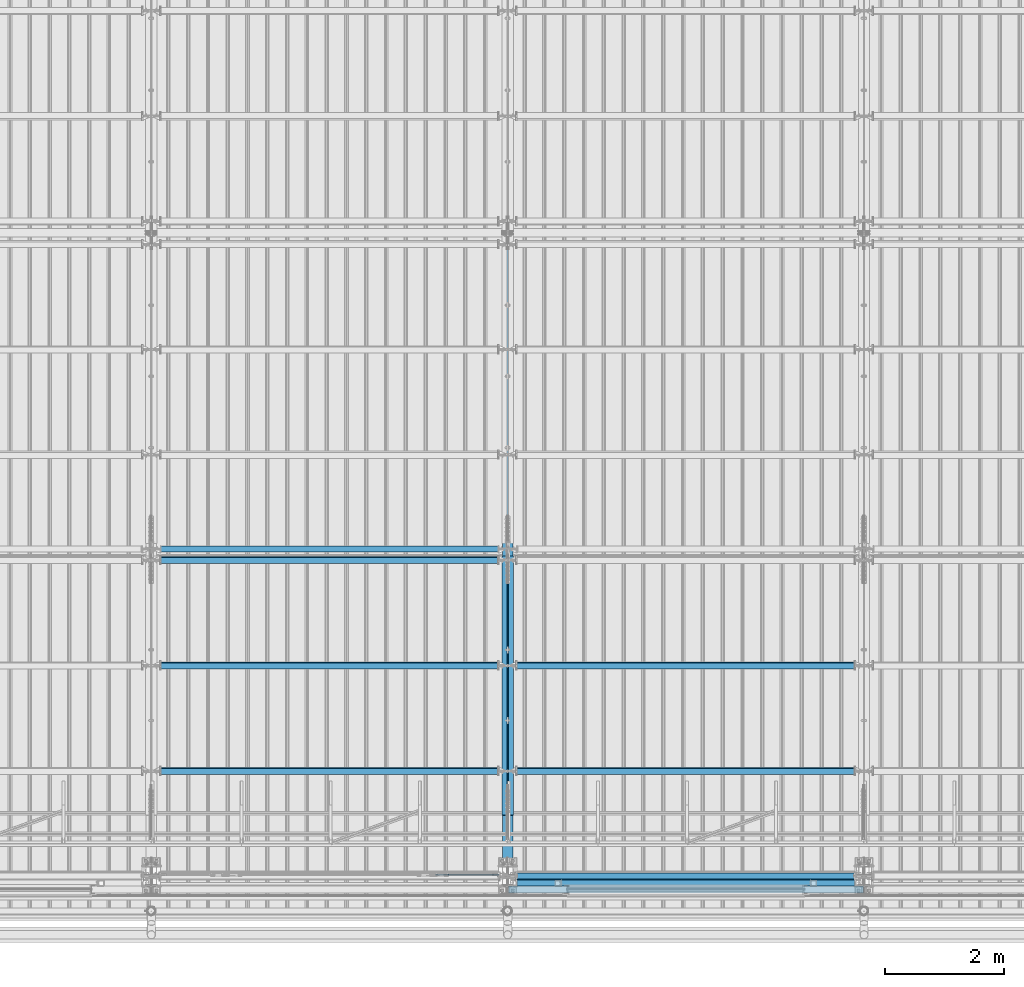
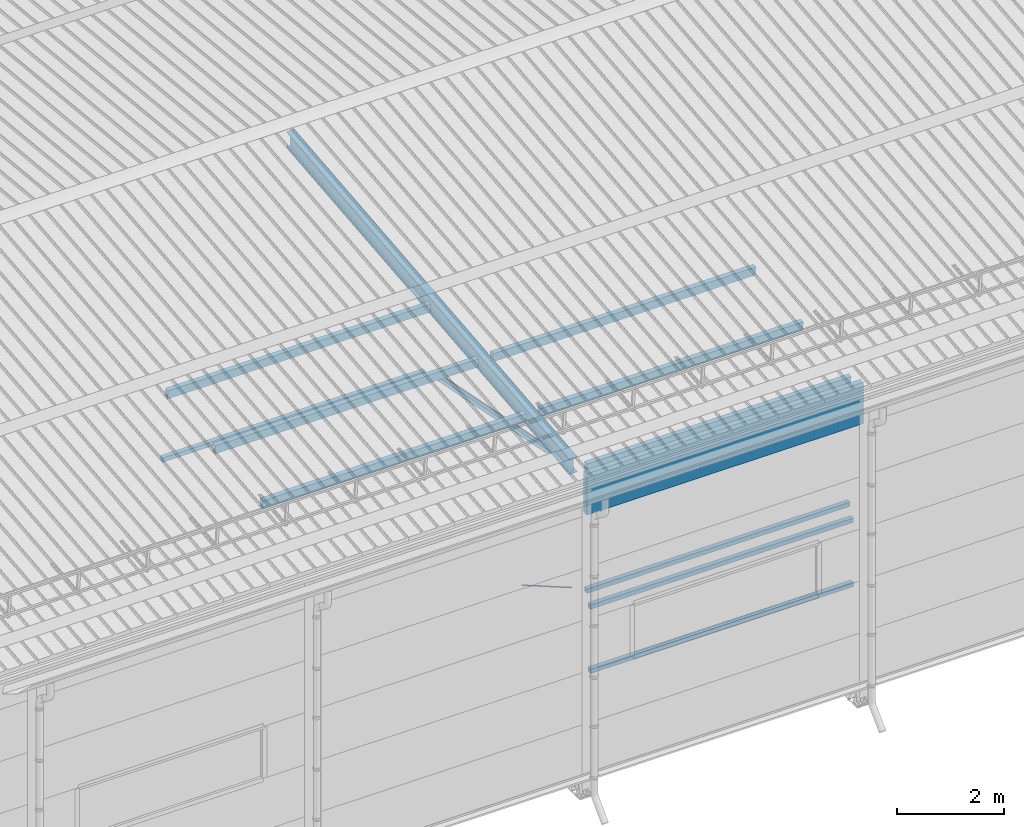
# One storey, part 254 of 709: 14 beams, 1 member, 1 opening, 15 elements without a shape of their own.
"""IFC4 building model written with IfcOpenShell, lengths in millimetres."""

from ifc_helpers import new_model, si_unit, direction, frame, origin_with_axes, place, context, subcontext, project, spatial, line, indexed_curve, outline, extrude, polygons, material, element, aggregate, save


model = new_model("IFC4")

# Units and contexts
model_context = context("Model", 3, precision=0.2, world=origin_with_axes(), true_north=direction((0.0, 1.0)))
body_context = subcontext(model_context, "Body", "Model", "MODEL_VIEW")
reference_context = subcontext(model_context, "Reference", "Model", "MODEL_VIEW")
ifc_project = project(units=[si_unit("LENGTHUNIT", "METRE", prefix="MILLI"), si_unit("AREAUNIT", "SQUARE_METRE"), si_unit("VOLUMEUNIT", "CUBIC_METRE"), si_unit("MASSUNIT", "GRAM", prefix="KILO"), si_unit("TIMEUNIT", "SECOND"), si_unit("PLANEANGLEUNIT", "RADIAN"), si_unit("SOLIDANGLEUNIT", "STERADIAN"), si_unit("THERMODYNAMICTEMPERATUREUNIT", "DEGREE_CELSIUS"), si_unit("LUMINOUSINTENSITYUNIT", "LUMEN")], contexts=[model_context])

# Site, building, storey
site_placement = place(None, origin_with_axes())
site = spatial("IfcSite", under=ifc_project, at=site_placement, CompositionType="ELEMENT")
building_placement = place(site_placement, origin_with_axes())
building = spatial("IfcBuilding", under=site, at=building_placement, Name="Undefined", CompositionType="ELEMENT")
storey_placement = place(building_placement, origin_with_axes())
storey = spatial("IfcBuildingStorey", under=building, at=storey_placement, Name="Undefined", CompositionType="ELEMENT", Elevation=0.0)

# Assembly, beam
assembly_1_placement = place(storey_placement, frame((28000.0, 346.0, 7089.70002), z_axis=(1.0, 0.0, 0.0), x_axis=(0.0, 0.9950371902, 0.099503719)))
assembly_1 = element("IfcElementAssembly", 1, at=assembly_1_placement, inside=storey)
ifc_material_1 = material(Name="C355-5", Category="STEEL")
beam_1_placement = place(assembly_1_placement, origin_with_axes())
beam_1 = element("IfcBeam", 2, at=beam_1_placement, material=ifc_material_1, ObjectType="432", context=body_context, shape_type="Tessellation", body=[
    polygons([(3.80474, -173.0, -87.0), (4.70474, -164.0, -87.0), (10665.6128, -164.0, -87.0), (10664.7128, -173.0, -87.0), (4.70474, -164.0, -3.0), (10665.6128, -164.0, -3.0), (37.50474, 164.0, -3.0), (10698.4128, 164.0, -3.0), (37.50474, 164.0, -87.0), (10698.4128, 164.0, -87.0), (38.40474, 173.0, -87.0), (10699.3128, 173.0, -87.0), (38.40474, 173.0, 87.0), (10699.3128, 173.0, 87.0), (37.50474, 164.0, 87.0), (10698.4128, 164.0, 87.0), (37.50474, 164.0, 3.0), (10698.4128, 164.0, 3.0), (4.70474, -164.0, 3.0), (10665.6128, -164.0, 3.0), (4.70474, -164.0, 87.0), (10665.6128, -164.0, 87.0), (3.80474, -173.0, 87.0), (10664.7128, -173.0, 87.0)], [[[1, 2, 3, 4]], [[2, 5, 6, 3]], [[5, 7, 8, 6]], [[7, 9, 10, 8]], [[9, 11, 12, 10]], [[11, 13, 14, 12]], [[13, 15, 16, 14]], [[15, 17, 18, 16]], [[17, 19, 20, 18]], [[19, 21, 22, 20]], [[21, 23, 24, 22]], [[23, 1, 4, 24]], [[6, 8, 10, 12, 14, 16, 18, 20, 22, 24, 4, 3]], [[23, 21, 19, 17, 15, 13, 11, 9, 7, 5, 2, 1]]], closed=True),
])
aggregate(assembly_1, [beam_1])

assembly_2_placement = place(storey_placement, frame((27949.0, 350.0596, 7109.99804), z_axis=(0.0, 0.1961161349, 0.9805806757), x_axis=(0.0, 0.9805806757, -0.1961161349)))
assembly_2 = element("IfcElementAssembly", 3, at=assembly_2_placement, inside=storey)
ifc_material_2 = material(Name="C345-5", Category="STEEL")
beam_2_placement = place(assembly_2_placement, origin_with_axes())
beam_2 = element("IfcBeam", 4, at=beam_2_placement, material=ifc_material_2, ObjectType="444", context=body_context, shape_type="Tessellation", body=[
    polygons([(868.11437, -45.0, -45.0), (868.11437, 45.0, -45.0), (5317.375, 45.0, -45.0), (5317.375, -45.0, -45.0), (868.11437, 45.0, -39.0), (5317.375, 45.0, -39.0), (868.11437, -39.0, -39.0), (5317.375, -39.0, -39.0), (868.11437, -39.0, 45.0), (5317.375, -39.0, 45.0), (868.11437, -45.0, 45.0), (5317.375, -45.0, 45.0)], [[[1, 2, 3, 4]], [[2, 5, 6, 3]], [[5, 7, 8, 6]], [[7, 9, 10, 8]], [[9, 11, 12, 10]], [[11, 1, 4, 12]], [[6, 8, 10, 12, 4, 3]], [[11, 9, 7, 5, 2, 1]]], closed=True),
])
aggregate(assembly_2, [beam_2])

assembly_3_placement = place(storey_placement, frame((28051.0, 5677.0596, 6044.59804), z_axis=(0.0, 0.1961161349, 0.9805806757), x_axis=(0.0, -0.9805806757, 0.1961161349)))
assembly_3 = element("IfcElementAssembly", 5, at=assembly_3_placement, inside=storey)
beam_3_placement = place(assembly_3_placement, origin_with_axes())
beam_3 = element("IfcBeam", 6, at=beam_3_placement, material=ifc_material_2, ObjectType="444", context=body_context, shape_type="Tessellation", body=[
    polygons([(115.12039, -45.0, -45.0), (115.12039, 45.0, -45.0), (4564.38102, 45.0, -45.0), (4564.38102, -45.0, -45.0), (115.12039, 45.0, -39.0), (4564.38102, 45.0, -39.0), (115.12039, -39.0, -39.0), (4564.38102, -39.0, -39.0), (115.12039, -39.0, 45.0), (4564.38102, -39.0, 45.0), (115.12039, -45.0, 45.0), (4564.38102, -45.0, 45.0)], [[[1, 2, 3, 4]], [[2, 5, 6, 3]], [[5, 7, 8, 6]], [[7, 9, 10, 8]], [[9, 11, 12, 10]], [[11, 1, 4, 12]], [[6, 8, 10, 12, 4, 3]], [[11, 9, 7, 5, 2, 1]]], closed=True),
])
aggregate(assembly_3, [beam_3])

# Assembly, member, voiding feature
assembly_4_placement = place(storey_placement, frame((26612.9509, 189.0, 4959.49238), z_axis=(0.0, -1.0, 0.0), x_axis=(0.9286065, 0.0, -0.371065989)))
assembly_4 = element("IfcElementAssembly", 7, at=assembly_4_placement, inside=storey)
member_placement = place(assembly_4_placement, origin_with_axes())
member = element("IfcMember", 8, at=member_placement, material=ifc_material_1, ObjectType="515", context=body_context, shape_type="Tessellation", body=[
    polygons([(1330.0, -5.0, 8.66025), (1330.0, -7.07107, 7.07107), (1330.0, -8.66025, 5.0), (1330.0, -9.65926, 2.58819), (1330.0, -10.0, 0.0), (1330.0, -9.65926, -2.58819), (1330.0, -8.66025, -5.0), (1330.0, -7.07107, -7.07107), (1330.0, -5.0, -8.66025), (1330.0, -2.58819, -9.65926), (1330.0, 0.0, -10.0), (1330.0, 2.58819, -9.65926), (1330.0, 5.0, -8.66025), (1330.0, 7.07107, -7.07107), (1330.0, 8.66025, -5.0), (1330.0, 9.65926, -2.58819), (1330.0, 10.0, 0.0), (1330.0, 9.65926, 2.58819), (1330.0, 8.66025, 5.0), (1330.0, 7.07107, 7.07107), (1330.0, 5.0, 8.66025), (1330.0, 2.58819, 9.65926), (1330.0, 0.0, 10.0), (1330.0, -2.58819, 9.65926), (190.0, 10.0, 0.0), (190.0, 9.65926, 2.58819), (190.0, 8.66025, 5.0), (190.0, 7.07107, 7.07107), (190.0, 5.0, 8.66025), (190.0, 2.58819, 9.65926), (190.0, 0.0, 10.0), (190.0, -2.58819, 9.65926), (190.0, -5.0, 8.66025), (190.0, -7.07107, 7.07107), (190.0, -8.66025, 5.0), (190.0, -9.65926, 2.58819), (190.0, -10.0, 0.0), (190.0, -9.65926, -2.58819), (190.0, -8.66025, -5.0), (190.0, -7.07107, -7.07107), (190.0, -5.0, -8.66025), (190.0, -2.58819, -9.65926), (190.0, 0.0, -10.0), (190.0, 2.58819, -9.65926), (190.0, 5.0, -8.66025), (190.0, 7.07107, -7.07107), (190.0, 8.66025, -5.0), (190.0, 9.65926, -2.58819), (10.0, 7.36122, 4.25), (190.0, 7.36122, 4.25), (190.0, 8.21037, 2.19996), (10.0, 8.21037, 2.19996), (10.0, 6.01041, 6.01041), (190.0, 6.01041, 6.01041), (10.0, 4.25, 7.36122), (190.0, 4.25, 7.36122), (10.0, 2.19996, 8.21037), (190.0, 2.19996, 8.21037), (10.0, 0.0, 8.5), (190.0, 0.0, 8.5), (10.0, -2.19996, 8.21037), (190.0, -2.19996, 8.21037), (10.0, -4.25, 7.36122), (190.0, -4.25, 7.36122), (10.0, -6.01041, 6.01041), (190.0, -6.01041, 6.01041), (10.0, -7.36122, 4.25), (190.0, -7.36122, 4.25), (10.0, -8.21037, 2.19996), (190.0, -8.21037, 2.19996), (10.0, -8.5, 0.0), (190.0, -8.5, 0.0), (10.0, -8.21037, -2.19996), (190.0, -8.21037, -2.19996), (10.0, -7.36122, -4.25), (190.0, -7.36122, -4.25), (10.0, -6.01041, -6.01041), (190.0, -6.01041, -6.01041), (10.0, -4.25, -7.36122), (190.0, -4.25, -7.36122), (10.0, -2.19996, -8.21037), (190.0, -2.19996, -8.21037), (10.0, 0.0, -8.5), (190.0, 0.0, -8.5), (10.0, 2.19996, -8.21037), (190.0, 2.19996, -8.21037), (10.0, 4.25, -7.36122), (190.0, 4.25, -7.36122), (10.0, 6.01041, -6.01041), (190.0, 6.01041, -6.01041), (10.0, 7.36122, -4.25), (190.0, 7.36122, -4.25), (10.0, 8.21037, -2.19996), (190.0, 8.21037, -2.19996), (10.0, 8.5, 0.0), (190.0, 8.5, 0.0)], [[[1, 2, 3, 4, 5, 6, 7, 8, 9, 10, 11, 12, 13, 14, 15, 16, 17, 18, 19, 20, 21, 22, 23, 24]], [[18, 17, 25, 26]], [[19, 18, 26, 27]], [[20, 19, 27, 28]], [[21, 20, 28, 29]], [[22, 21, 29, 30]], [[23, 22, 30, 31]], [[24, 23, 31, 32]], [[1, 24, 32, 33]], [[2, 1, 33, 34]], [[3, 2, 34, 35]], [[4, 3, 35, 36]], [[5, 4, 36, 37]], [[6, 5, 37, 38]], [[7, 6, 38, 39]], [[8, 7, 39, 40]], [[9, 8, 40, 41]], [[10, 9, 41, 42]], [[11, 10, 42, 43]], [[12, 11, 43, 44]], [[13, 12, 44, 45]], [[14, 13, 45, 46]], [[15, 14, 46, 47]], [[16, 15, 47, 48]], [[17, 16, 48, 25]], [[25, 48, 47, 46, 45, 44, 43, 42, 41, 40, 39, 38, 37, 36, 35, 34, 33, 32, 31, 30, 29, 28, 27, 26], [74, 76, 78, 80, 82, 84, 86, 88, 90, 92, 94, 96, 51, 50, 54, 56, 58, 60, 62, 64, 66, 68, 70, 72]], [[49, 50, 51, 52]], [[53, 54, 50, 49]], [[55, 56, 54, 53]], [[57, 58, 56, 55]], [[59, 60, 58, 57]], [[61, 62, 60, 59]], [[63, 64, 62, 61]], [[65, 66, 64, 63]], [[67, 68, 66, 65]], [[69, 70, 68, 67]], [[71, 72, 70, 69]], [[73, 74, 72, 71]], [[75, 76, 74, 73]], [[77, 78, 76, 75]], [[79, 80, 78, 77]], [[81, 82, 80, 79]], [[83, 84, 82, 81]], [[85, 86, 84, 83]], [[87, 88, 86, 85]], [[89, 90, 88, 87]], [[91, 92, 90, 89]], [[93, 94, 92, 91]], [[95, 96, 94, 93]], [[52, 51, 96, 95]], [[91, 89, 87, 85, 83, 81, 79, 77, 75, 73, 71, 69, 67, 65, 63, 61, 59, 57, 55, 53, 49, 52, 95, 93]]], closed=True),
])
voiding_feature_placement = place(member_placement, frame((10.0, 0.0, 0.0), z_axis=(0.0, -1.0, 0.0), x_axis=(1.0, 0.0, 0.0)))
element("IfcVoidingFeature", 9, at=voiding_feature_placement, cuts=member, PredefinedType="HOLE", context=reference_context, identifier="Reference", shape_type="SolidModel", body=[
    extrude(outline(indexed_curve([(10.5, 0.0), (10.14222, 2.7176), (9.09327, 5.25), (7.42462, 7.42462), (5.25, 9.09327), (2.7176, 10.14222), (0.0, 10.5), (-2.7176, 10.14222), (-5.25, 9.09327), (-7.42462, 7.42462), (-9.09327, 5.25), (-10.14222, 2.7176), (-10.5, 0.0), (-10.14222, -2.7176), (-9.09327, -5.25), (-7.42462, -7.42462), (-5.25, -9.09327), (-2.7176, -10.14222), (0.0, -10.5), (2.7176, -10.14222), (5.25, -9.09327), (7.42462, -7.42462), (9.09327, -5.25), (10.14222, -2.7176)], segments=[line(1, 2, 3, 4, 5, 6, 7, 8, 9, 10, 11, 12, 13, 14, 15, 16, 17, 18, 19, 20, 21, 22, 23, 24, 1)])), frame((0.0, 0.0, 0.0), z_axis=(-1.0, 0.0, 0.0), x_axis=(0.0, 0.0, 1.0)), (0.0, 0.0, -1.0), 180.0),
])
aggregate(assembly_4, [member])

# Assembly, beam
assembly_5_placement = place(storey_placement, frame((28000.0, 50.0, 2550.0), z_axis=(0.0, 0.0, -1.0), x_axis=(1.0, 0.0, 0.0)))
assembly_5 = element("IfcElementAssembly", 10, at=assembly_5_placement, inside=storey)
ifc_material_3 = material(Name="C355", Category="STEEL")
beam_4_placement = place(assembly_5_placement, origin_with_axes())
beam_4 = element("IfcBeam", 11, at=beam_4_placement, material=ifc_material_3, ObjectType="545", context=body_context, shape_type="Tessellation", body=[
    polygons([(155.0, -47.0, -47.0), (155.0, -47.0, 47.0), (5845.0, -47.0, 47.0), (5845.0, -47.0, -47.0), (155.0, 47.0, 47.0), (5845.0, 47.0, 47.0), (155.0, 47.0, -47.0), (5845.0, 47.0, -47.0), (155.0, -50.0, -50.0), (155.0, 50.0, -50.0), (5845.0, 50.0, -50.0), (5845.0, -50.0, -50.0), (155.0, 50.0, 50.0), (5845.0, 50.0, 50.0), (155.0, -50.0, 50.0), (5845.0, -50.0, 50.0)], [[[1, 2, 3, 4]], [[2, 5, 6, 3]], [[5, 7, 8, 6]], [[7, 1, 4, 8]], [[9, 10, 11, 12]], [[10, 13, 14, 11]], [[13, 15, 16, 14]], [[15, 9, 12, 16]], [[14, 16, 12, 11], [6, 8, 4, 3]], [[15, 13, 10, 9], [7, 5, 2, 1]]], closed=True),
])
aggregate(assembly_5, [beam_4])

assembly_6_placement = place(storey_placement, frame((28000.0, 50.0, 4020.0), z_axis=(0.0, 0.0, -1.0), x_axis=(1.0, 0.0, 0.0)))
assembly_6 = element("IfcElementAssembly", 12, at=assembly_6_placement, inside=storey)
beam_5_placement = place(assembly_6_placement, origin_with_axes())
beam_5 = element("IfcBeam", 13, at=beam_5_placement, material=ifc_material_3, ObjectType="545", context=body_context, shape_type="Tessellation", body=[
    polygons([(155.0, -47.0, -47.0), (155.0, -47.0, 47.0), (5845.0, -47.0, 47.0), (5845.0, -47.0, -47.0), (155.0, 47.0, 47.0), (5845.0, 47.0, 47.0), (155.0, 47.0, -47.0), (5845.0, 47.0, -47.0), (155.0, -50.0, -50.0), (155.0, 50.0, -50.0), (5845.0, 50.0, -50.0), (5845.0, -50.0, -50.0), (155.0, 50.0, 50.0), (5845.0, 50.0, 50.0), (155.0, -50.0, 50.0), (5845.0, -50.0, 50.0)], [[[1, 2, 3, 4]], [[2, 5, 6, 3]], [[5, 7, 8, 6]], [[7, 1, 4, 8]], [[9, 10, 11, 12]], [[10, 13, 14, 11]], [[13, 15, 16, 14]], [[15, 9, 12, 16]], [[14, 16, 12, 11], [6, 8, 4, 3]], [[15, 13, 10, 9], [7, 5, 2, 1]]], closed=True),
])
aggregate(assembly_6, [beam_5])

assembly_7_placement = place(storey_placement, frame((28000.0, 173.0, 4310.0), z_axis=(0.0, 0.0, -1.0), x_axis=(1.0, 0.0, 0.0)))
assembly_7 = element("IfcElementAssembly", 14, at=assembly_7_placement, inside=storey)
beam_6_placement = place(assembly_7_placement, origin_with_axes())
beam_6 = element("IfcBeam", 15, at=beam_6_placement, material=ifc_material_3, ObjectType="546", context=body_context, shape_type="Tessellation", body=[
    polygons([(155.0, -47.0, -47.0), (155.0, -47.0, 47.0), (5845.0, -47.0, 47.0), (5845.0, -47.0, -47.0), (155.0, 47.0, 47.0), (5845.0, 47.0, 47.0), (155.0, 47.0, -47.0), (5845.0, 47.0, -47.0), (155.0, -50.0, -50.0), (155.0, 50.0, -50.0), (5845.0, 50.0, -50.0), (5845.0, -50.0, -50.0), (155.0, 50.0, 50.0), (5845.0, 50.0, 50.0), (155.0, -50.0, 50.0), (5845.0, -50.0, 50.0)], [[[1, 2, 3, 4]], [[2, 5, 6, 3]], [[5, 7, 8, 6]], [[7, 1, 4, 8]], [[9, 10, 11, 12]], [[10, 13, 14, 11]], [[13, 15, 16, 14]], [[15, 9, 12, 16]], [[14, 16, 12, 11], [6, 8, 4, 3]], [[15, 13, 10, 9], [7, 5, 2, 1]]], closed=True),
])
aggregate(assembly_7, [beam_6])

assembly_8_placement = place(storey_placement, frame((22000.0, 5673.0, 6074.30002), z_axis=(0.0, -1.0, 0.0), x_axis=(1.0, 0.0, 0.0)))
assembly_8 = element("IfcElementAssembly", 16, at=assembly_8_placement, inside=storey)
beam_7_placement = place(assembly_8_placement, origin_with_axes())
beam_7 = element("IfcBeam", 17, at=beam_7_placement, material=ifc_material_3, ObjectType="557", context=body_context, shape_type="Tessellation", body=[
    polygons([(162.0, -47.0, -47.0), (162.0, -47.0, 47.0), (5838.0, -47.0, 47.0), (5838.0, -47.0, -47.0), (162.0, 47.0, 47.0), (5838.0, 47.0, 47.0), (162.0, 47.0, -47.0), (5838.0, 47.0, -47.0), (162.0, -50.0, -50.0), (162.0, 50.0, -50.0), (5838.0, 50.0, -50.0), (5838.0, -50.0, -50.0), (162.0, 50.0, 50.0), (5838.0, 50.0, 50.0), (162.0, -50.0, 50.0), (5838.0, -50.0, 50.0)], [[[1, 2, 3, 4]], [[2, 5, 6, 3]], [[5, 7, 8, 6]], [[7, 1, 4, 8]], [[9, 10, 11, 12]], [[10, 13, 14, 11]], [[13, 15, 16, 14]], [[15, 9, 12, 16]], [[14, 16, 12, 11], [6, 8, 4, 3]], [[15, 13, 10, 9], [7, 5, 2, 1]]], closed=True),
])
aggregate(assembly_8, [beam_7])

assembly_9_placement = place(storey_placement, frame((22000.0, 1936.65012, 7322.12913), z_axis=(0.0, 0.9950371902, 0.099503719), x_axis=(1.0, 0.0, 0.0)))
assembly_9 = element("IfcElementAssembly", 18, at=assembly_9_placement, inside=storey)
beam_8_placement = place(assembly_9_placement, origin_with_axes())
beam_8 = element("IfcBeam", 19, at=beam_8_placement, material=ifc_material_3, ObjectType="579", context=body_context, shape_type="Tessellation", body=[
    polygons([(155.0, -96.0, -46.0), (155.0, -96.0, 46.0), (5845.0, -96.0, 46.0), (5845.0, -96.0, -46.0), (155.0, 96.0, 46.0), (5845.0, 96.0, 46.0), (155.0, 96.0, -46.0), (5845.0, 96.0, -46.0), (155.0, -100.0, -50.0), (155.0, 100.0, -50.0), (5845.0, 100.0, -50.0), (5845.0, -100.0, -50.0), (155.0, 100.0, 50.0), (5845.0, 100.0, 50.0), (155.0, -100.0, 50.0), (5845.0, -100.0, 50.0)], [[[1, 2, 3, 4]], [[2, 5, 6, 3]], [[5, 7, 8, 6]], [[7, 1, 4, 8]], [[9, 10, 11, 12]], [[10, 13, 14, 11]], [[13, 15, 16, 14]], [[15, 9, 12, 16]], [[14, 16, 12, 11], [6, 8, 4, 3]], [[15, 13, 10, 9], [7, 5, 2, 1]]], closed=True),
])
aggregate(assembly_9, [beam_8])

assembly_10_placement = place(storey_placement, frame((22000.0, 3713.34988, 7499.7991), z_axis=(0.0, 0.9950371902, 0.099503719), x_axis=(1.0, 0.0, 0.0)))
assembly_10 = element("IfcElementAssembly", 20, at=assembly_10_placement, inside=storey)
beam_9_placement = place(assembly_10_placement, origin_with_axes())
beam_9 = element("IfcBeam", 21, at=beam_9_placement, material=ifc_material_3, ObjectType="579", context=body_context, shape_type="Tessellation", body=[
    polygons([(155.0, -96.0, -46.0), (155.0, -96.0, 46.0), (5845.0, -96.0, 46.0), (5845.0, -96.0, -46.0), (155.0, 96.0, 46.0), (5845.0, 96.0, 46.0), (155.0, 96.0, -46.0), (5845.0, 96.0, -46.0), (155.0, -100.0, -50.0), (155.0, 100.0, -50.0), (5845.0, 100.0, -50.0), (5845.0, -100.0, -50.0), (155.0, 100.0, 50.0), (5845.0, 100.0, 50.0), (155.0, -100.0, 50.0), (5845.0, -100.0, 50.0)], [[[1, 2, 3, 4]], [[2, 5, 6, 3]], [[5, 7, 8, 6]], [[7, 1, 4, 8]], [[9, 10, 11, 12]], [[10, 13, 14, 11]], [[13, 15, 16, 14]], [[15, 9, 12, 16]], [[14, 16, 12, 11], [6, 8, 4, 3]], [[15, 13, 10, 9], [7, 5, 2, 1]]], closed=True),
])
aggregate(assembly_10, [beam_9])

assembly_11_placement = place(storey_placement, frame((22000.0, 5490.04963, 7677.46908), z_axis=(0.0, 0.9950371902, 0.099503719), x_axis=(1.0, 0.0, 0.0)))
assembly_11 = element("IfcElementAssembly", 22, at=assembly_11_placement, inside=storey)
beam_10_placement = place(assembly_11_placement, origin_with_axes())
beam_10 = element("IfcBeam", 23, at=beam_10_placement, material=ifc_material_3, ObjectType="579", context=body_context, shape_type="Tessellation", body=[
    polygons([(155.0, -96.0, -46.0), (155.0, -96.0, 46.0), (5845.0, -96.0, 46.0), (5845.0, -96.0, -46.0), (155.0, 96.0, 46.0), (5845.0, 96.0, 46.0), (155.0, 96.0, -46.0), (5845.0, 96.0, -46.0), (155.0, -100.0, -50.0), (155.0, 100.0, -50.0), (5845.0, 100.0, -50.0), (5845.0, -100.0, -50.0), (155.0, 100.0, 50.0), (5845.0, 100.0, 50.0), (155.0, -100.0, 50.0), (5845.0, -100.0, 50.0)], [[[1, 2, 3, 4]], [[2, 5, 6, 3]], [[5, 7, 8, 6]], [[7, 1, 4, 8]], [[9, 10, 11, 12]], [[10, 13, 14, 11]], [[13, 15, 16, 14]], [[15, 9, 12, 16]], [[14, 16, 12, 11], [6, 8, 4, 3]], [[15, 13, 10, 9], [7, 5, 2, 1]]], closed=True),
])
aggregate(assembly_11, [beam_10])

assembly_12_placement = place(storey_placement, frame((28000.0, 158.95533, 7154.40952), z_axis=(0.0, 0.9950371902, 0.099503719), x_axis=(1.0, 0.0, 0.0)))
assembly_12 = element("IfcElementAssembly", 24, at=assembly_12_placement, inside=storey)
beam_11_placement = place(assembly_12_placement, origin_with_axes())
beam_11 = element("IfcBeam", 25, at=beam_11_placement, material=ifc_material_3, ObjectType="578", context=body_context, shape_type="Tessellation", body=[
    polygons([(145.0, -86.0, -46.0), (145.0, -86.0, 46.0), (5855.0, -86.0, 46.0), (5855.0, -86.0, -46.0), (145.0, 86.0, 46.0), (5855.0, 86.0, 46.0), (145.0, 86.0, -46.0), (5855.0, 86.0, -46.0), (145.0, -90.0, -50.0), (145.0, 90.0, -50.0), (5855.0, 90.0, -50.0), (5855.0, -90.0, -50.0), (145.0, 90.0, 50.0), (5855.0, 90.0, 50.0), (145.0, -90.0, 50.0), (5855.0, -90.0, 50.0)], [[[1, 2, 3, 4]], [[2, 5, 6, 3]], [[5, 7, 8, 6]], [[7, 1, 4, 8]], [[9, 10, 11, 12]], [[10, 13, 14, 11]], [[13, 15, 16, 14]], [[15, 9, 12, 16]], [[14, 16, 12, 11], [6, 8, 4, 3]], [[15, 13, 10, 9], [7, 5, 2, 1]]], closed=True),
])
aggregate(assembly_12, [beam_11])

assembly_13_placement = place(storey_placement, frame((28000.0, 1936.65012, 7322.12913), z_axis=(0.0, 0.9950371902, 0.099503719), x_axis=(1.0, 0.0, 0.0)))
assembly_13 = element("IfcElementAssembly", 26, at=assembly_13_placement, inside=storey)
beam_12_placement = place(assembly_13_placement, origin_with_axes())
beam_12 = element("IfcBeam", 27, at=beam_12_placement, material=ifc_material_3, ObjectType="579", context=body_context, shape_type="Tessellation", body=[
    polygons([(155.0, -96.0, -46.0), (155.0, -96.0, 46.0), (5845.0, -96.0, 46.0), (5845.0, -96.0, -46.0), (155.0, 96.0, 46.0), (5845.0, 96.0, 46.0), (155.0, 96.0, -46.0), (5845.0, 96.0, -46.0), (155.0, -100.0, -50.0), (155.0, 100.0, -50.0), (5845.0, 100.0, -50.0), (5845.0, -100.0, -50.0), (155.0, 100.0, 50.0), (5845.0, 100.0, 50.0), (155.0, -100.0, 50.0), (5845.0, -100.0, 50.0)], [[[1, 2, 3, 4]], [[2, 5, 6, 3]], [[5, 7, 8, 6]], [[7, 1, 4, 8]], [[9, 10, 11, 12]], [[10, 13, 14, 11]], [[13, 15, 16, 14]], [[15, 9, 12, 16]], [[14, 16, 12, 11], [6, 8, 4, 3]], [[15, 13, 10, 9], [7, 5, 2, 1]]], closed=True),
])
aggregate(assembly_13, [beam_12])

assembly_14_placement = place(storey_placement, frame((28000.0, 3713.34988, 7499.7991), z_axis=(0.0, 0.9950371902, 0.099503719), x_axis=(1.0, 0.0, 0.0)))
assembly_14 = element("IfcElementAssembly", 28, at=assembly_14_placement, inside=storey)
beam_13_placement = place(assembly_14_placement, origin_with_axes())
beam_13 = element("IfcBeam", 29, at=beam_13_placement, material=ifc_material_3, ObjectType="579", context=body_context, shape_type="Tessellation", body=[
    polygons([(155.0, -96.0, -46.0), (155.0, -96.0, 46.0), (5845.0, -96.0, 46.0), (5845.0, -96.0, -46.0), (155.0, 96.0, 46.0), (5845.0, 96.0, 46.0), (155.0, 96.0, -46.0), (5845.0, 96.0, -46.0), (155.0, -100.0, -50.0), (155.0, 100.0, -50.0), (5845.0, 100.0, -50.0), (5845.0, -100.0, -50.0), (155.0, 100.0, 50.0), (5845.0, 100.0, 50.0), (155.0, -100.0, 50.0), (5845.0, -100.0, 50.0)], [[[1, 2, 3, 4]], [[2, 5, 6, 3]], [[5, 7, 8, 6]], [[7, 1, 4, 8]], [[9, 10, 11, 12]], [[10, 13, 14, 11]], [[13, 15, 16, 14]], [[15, 9, 12, 16]], [[14, 16, 12, 11], [6, 8, 4, 3]], [[15, 13, 10, 9], [7, 5, 2, 1]]], closed=True),
])
aggregate(assembly_14, [beam_13])

assembly_15_placement = place(storey_placement, frame((28010.0, -60.0, 6845.0), z_axis=(0.0, 0.0, -1.0), x_axis=(1.0, 0.0, 0.0)))
assembly_15 = element("IfcElementAssembly", 30, at=assembly_15_placement, inside=storey)
ifc_material_4 = material(Name="Insulation", Category="Insulation")
beam_14_placement = place(assembly_15_placement, origin_with_axes())
beam_14 = element("IfcBeam", 31, at=beam_14_placement, material=ifc_material_4, ObjectType="P-108", context=body_context, shape_type="Tessellation", body=[
    polygons([(0.0, 60.0, 595.0), (0.0, -60.0, 595.0), (5980.0, -60.0, 595.0), (5980.0, 60.0, 595.0), (5980.0, 60.0, -351.923), (0.0, 60.0, -351.923), (0.0, -60.0, -351.923), (5980.0, -60.0, -351.923)], [[[1, 2, 3, 4]], [[1, 4, 5, 6]], [[2, 1, 6, 7]], [[3, 2, 7, 8]], [[4, 3, 8, 5]], [[7, 6, 5, 8]]], closed=True),
])
aggregate(assembly_15, [beam_14])

save(model, "model.ifc")
